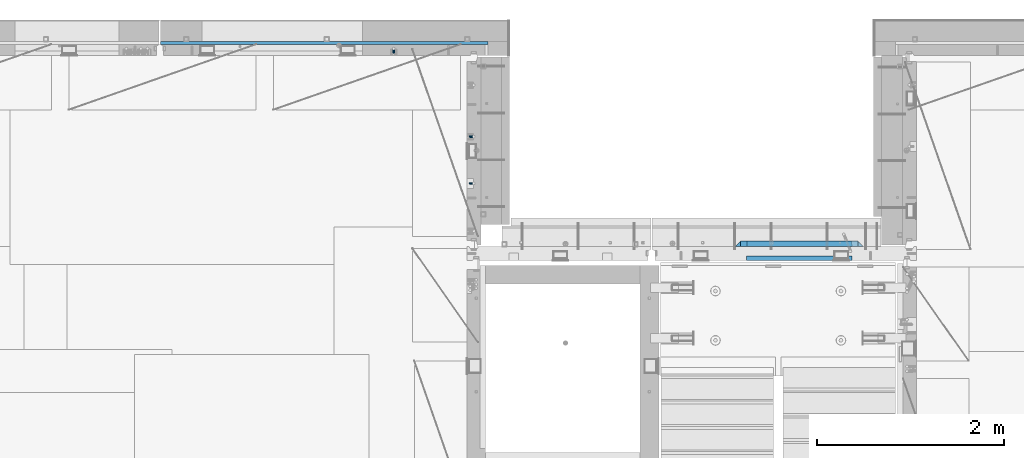
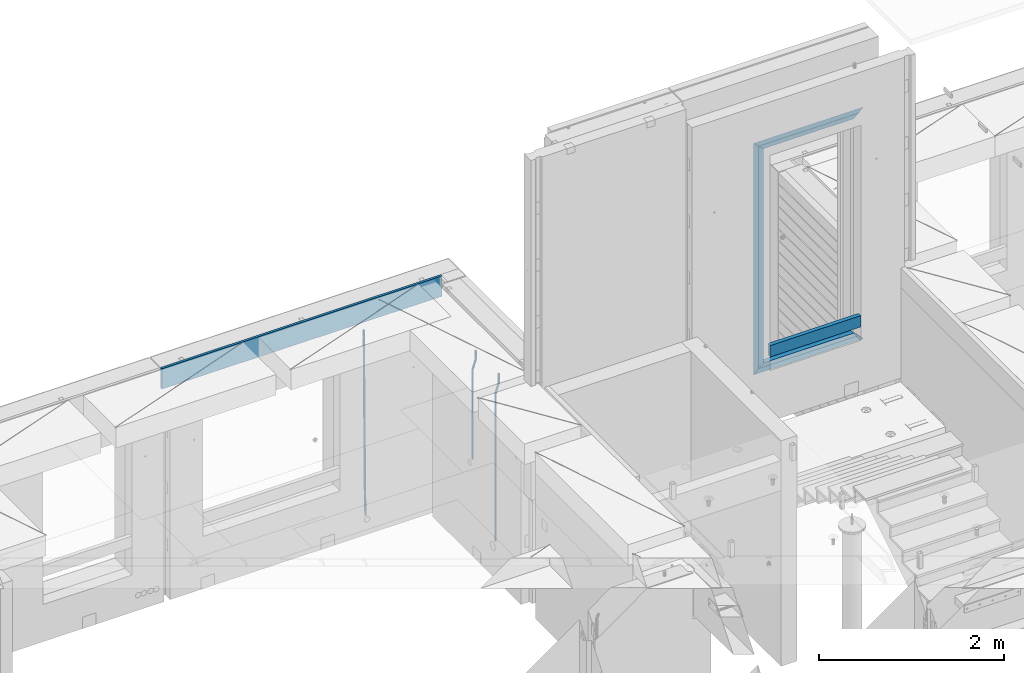
# One storey, part 122 of 352: 11 beams, 3 elements without a shape of their own.
"""IFC2X3 building model written with IfcOpenShell, lengths in millimetres."""

from ifc_helpers import new_model, si_unit, frame, origin_with_axes, place, context, subcontext, project, spatial, faceted_brep, material, type_object, element, aggregate, save


model = new_model("IFC2X3")

# Units and contexts
model_context = context("Model", 3, precision=1e-05, world=origin_with_axes())
body_context = subcontext(model_context, "Body", "Model", "MODEL_VIEW")
ifc_project = project(units=[si_unit("LENGTHUNIT", "METRE", prefix="MILLI"), si_unit("AREAUNIT", "SQUARE_METRE"), si_unit("VOLUMEUNIT", "CUBIC_METRE"), si_unit("MASSUNIT", "GRAM", prefix="KILO"), si_unit("TIMEUNIT", "SECOND"), si_unit("PLANEANGLEUNIT", "RADIAN"), si_unit("SOLIDANGLEUNIT", "STERADIAN"), si_unit("THERMODYNAMICTEMPERATUREUNIT", "DEGREE_CELSIUS"), si_unit("LUMINOUSINTENSITYUNIT", "LUMEN")], contexts=[model_context])

# Site, building, storey
site_placement = place(None, origin_with_axes())
site = spatial("IfcSite", under=ifc_project, at=site_placement, CompositionType="ELEMENT")
building_placement = place(site_placement, origin_with_axes())
building = spatial("IfcBuilding", under=site, at=building_placement, CompositionType="ELEMENT")
storey_placement = place(building_placement, origin_with_axes())
storey = spatial("IfcBuildingStorey", under=building, at=storey_placement, Name="6", CompositionType="ELEMENT", Elevation=0.0)

# Assembly, beam
assembly_1_placement = place(storey_placement, origin_with_axes())
assembly_1 = element("IfcElementAssembly", 1, at=assembly_1_placement, inside=storey, AssemblyPlace="NOTDEFINED", PredefinedType="REINFORCEMENT_UNIT")
ifc_material_1 = material()
beam_type_1 = type_object("IfcBeamType", Name="D20", PredefinedType="NOTDEFINED")
beam_1_placement = place(assembly_1_placement, frame((16830.0000000039, 22654.999995444, 96990.0), z_axis=(-0.000205762999925498, 0.999642804629538, -0.0267249099901004), x_axis=(4.30000201928125e-08, 0.0267249099948059, 0.999642825806181)))
beam_1 = element("IfcBeam", 2, at=beam_1_placement, type_object=beam_type_1, material=ifc_material_1, Name="JM20", ObjectType="D20", context=body_context, shape_type="Brep", body=[
    faceted_brep([(0.0, -10.0, 0.0), (-4.19531716033816e-08, -7.07106781186667, -7.07106781187031), (60.4266690400545, -7.0710677960451, -7.07106780570757), (60.4266690441291, -9.99999998418934, 6.15546014159918e-09), (0.0, 0.0, -10.0), (60.426669036824, 1.58106558956206e-08, -9.99999999384454), (4.196772351861e-08, 7.07106781186303, -7.07106781186667), (60.4266690363438, 7.07106782768096, -7.07106780570757), (0.0, 10.0, 0.0), (60.4266690388904, 10.0000000158179, 6.15182216279209e-09), (4.196772351861e-08, 7.07106781185939, 7.07106781185939), (60.4266690429649, 7.07106782768096, 7.07106781802577), (0.0, 0.0, 10.0), (60.4266690461809, 1.58179318532348e-08, 10.0000000061555), (-4.19531716033816e-08, -7.07106781187031, 7.07106781185939), (60.4266690466611, -7.07106779605238, 7.07106781802213), (61.0378400410118, -7.07106779588503, -7.07106780564936), (60.991799419251, -9.99999998403655, 6.21366780251265e-09), (61.0569027789461, 1.5985278878361e-08, -9.99999999378269), (61.0378209396877, 7.07106782784831, -7.07106780564936), (60.9917724058905, 10.0000000159635, 6.21366780251265e-09), (60.9457317841297, 7.07106782781193, 7.0710678180767), (60.9266690461809, 1.59488990902901e-08, 10.0000000062028), (60.9457508854539, -7.07106779591413, 7.0710678180767), (61.6489592143771, -7.07106614513759, -7.06310863441468), (61.5568818710308, -9.9999984576425, 0.00735959856683621), (61.6870830769039, 1.71821739058942e-06, -9.99179257185824), (61.6489210170112, 7.07106947854481, -7.06310888312146), (61.556827851804, 10.0000015422847, 0.00735924683976918), (61.4647505084577, 7.07106922979438, 7.07782747982128), (61.4266266459163, 1.36643211590126e-06, 10.0065114172685), (61.464788705809, -7.07106639389531, 7.07782772852806), (176.543135720174, -7.07075579406956, -5.56673531796696), (176.451058376813, -9.99968810657447, 1.50373291501455), (176.581259582701, 0.000312069292704109, -8.49541925541052), (176.543097522794, 7.07137982961285, -5.56673556667374), (176.451004357587, 10.00031189336, 1.50373256329476), (176.35892701424, 7.07137958085514, 8.57420079627263), (176.320803151699, 0.000311717507429421, 11.5028847337162), (176.358965211621, -7.07075604281999, 8.57420104497578), (177.098753836006, -7.07075429323595, -5.55949898843028), (176.98362511232, -9.99968666800123, 1.510669025065), (177.146421932586, 0.000313595905026887, -8.48805862247536), (177.098706077581, 7.07138133041735, -5.55949936166144), (176.983557571715, 10.0003133318824, 1.51066849724157), (176.868428848029, 7.07138095712435, 8.58083651073321), (176.820760751449, 0.000313067976094317, 11.5093961447819), (176.868476606425, -7.07075466652896, 8.58083688396073), (177.654312950661, -7.07075204110879, -5.54863964998367), (177.516135294456, -9.99968450931192, 1.52107783331303), (177.711524267797, 0.000315886711177882, -8.47701274570863), (177.654255632195, 7.07138358250813, -5.54864021007961), (177.516054233929, 10.0003154905207, 1.5210770412159), (177.377876577739, 7.0713830223176, 8.59079452451624), (177.320665260588, 0.000315094497636892, 11.5191676202448), (177.377933896176, -7.07075260129932, 8.59079508461218), (299.436796249574, -7.07025836271714, -3.1681962331204), (299.298618593355, -9.99919083092027, 3.90152125031091), (299.494007566798, 0.000809565110102994, -6.09656932889993), (299.436738931283, 7.07187726089978, -3.16819679320906), (299.298537533061, 10.0008091689197, 3.90152045822106), (299.160359876842, 7.07187670072017, 10.9712379416487), (299.103148559603, 0.000808772889286047, 13.8996110374392), (299.160417195119, -7.07025892290039, 10.9712385017483), (299.98743051647, -7.07025613056248, -3.15743315966392), (299.971788958996, -9.99918809853989, 3.91467979818117), (299.993912075952, 0.000811591617093654, -6.08679785393178), (299.987423933868, 7.07187949325817, -3.1574327280432), (299.971753863239, 10.0008119014747, 3.91467990454839), (299.95611230444, 7.07187992653053, 10.9867922621015), (299.949630744944, 0.000812204350950196, 13.9161569563694), (299.956118887014, -7.07025569729012, 10.9867918304735), (300.538107039494, -7.07025785017686, -3.16575821840888), (300.644985195438, -9.99919020432935, 3.90450175465594), (300.493854948218, 0.000810030429420294, -6.09435592770024), (300.538151196495, 7.071877773491, -3.16575855385963), (300.645047642858, 10.0008097955724, 3.90450128024895), (300.751925798773, 7.07187744142357, 10.9747612533101), (300.796177890064, 0.000809560813650023, 13.9033589625978), (300.751881641787, -7.07025818224065, 10.9747615887682), (2293.36490490142, -7.07648090940347, -33.2930642912361), (2293.47178305736, -10.0054132635523, -26.2228043181785), (2293.32065281013, -0.00541302880083094, -36.2216620005347), (2293.36494905842, 7.06565471425711, -33.2930646266868), (2293.47184550477, 9.99458673634581, -26.2228047925819), (2293.57872366071, 7.06565438219332, -19.1525448195243), (2293.62297575199, -0.00541349841296324, -16.2239471102366), (2293.57867950371, -7.0764812414709, -19.1525444840736), (2294.0658245362, -7.07648309818615, -33.3036607065333), (2294.05312277409, -10.0054150789219, -26.2315929392535), (2294.10928714235, -0.00541549149056664, -36.2335844756526), (2294.15805078732, 7.06565223761572, -33.3050546393533), (2294.18355038921, 9.99458451388637, -26.2335642579346), (2294.17084862708, 7.06565253314329, -19.1614964906439), (2294.12738602093, -0.00541507354500936, -16.2315727215355), (2294.07862237596, -7.07648280265857, -19.1601025578348), (2294.76670261032, -7.08562269121467, -33.294332712383), (2294.63442802057, -10.0129954178956, -26.2238563411993), (2294.89787471293, -0.0156988342423574, -36.2230891548279), (2294.95110548967, 7.05531064255774, -33.2944998654275), (2294.89521307347, 9.98530428734011, -26.2240927312887), (2294.76293848372, 7.0579315606592, -19.1536163601049), (2294.63176638114, -0.0119922963167483, -16.2248599176673), (2294.57853560438, -7.08300177311321, -19.1534492070678), (2316.52657204497, -7.36937582653991, -33.0047303660212), (2316.39429745522, -10.2967485532172, -25.9342539948302), (2316.65774414754, -0.299451969567599, -35.9334868084661), (2316.7109749243, 6.7715575072325, -33.0048975190657), (2316.65508250811, 9.70155115201487, -25.9344903849269), (2316.52280791836, 6.7741784253376, -18.8640140137468), (2316.39163581574, -0.295745431634714, -15.9352575713092), (2316.33840503903, -7.36675490843481, -18.863846860706), (2317.16202064224, -7.37766220584308, -32.9962731735213), (2317.05438744847, -10.3053562613532, -25.9254688497131), (2317.23607125619, -0.306993473008333, -35.925789846493), (2317.23316144495, 6.76474808850253, -32.9979477328052), (2317.15499573652, 9.6950321815566, -25.9278370341635), (2317.04736254275, 6.7673381260538, -18.8570327103698), (2316.97331192881, -0.303330606784584, -15.9275160373909), (2316.97622174003, -7.37507216829545, -18.8553581510787), (2317.79752306276, -7.37578610372293, -32.9880110666527), (2317.71453320107, -10.3033876998124, -25.9168792378296), (2317.81444760226, -0.305295583297266, -35.918287695793), (2317.75539265381, 6.76628640723357, -32.9911928173897), (2317.65495180529, 9.69652304524061, -25.9213789128698), (2317.5719619436, 6.76892144914746, -18.8502470840467), (2317.55503740412, -0.301569071270933, -15.9199704549137), (2317.61409235255, -7.3731510618054, -18.847065333317), (2417.8183084176, -7.07752398473531, -31.6906369377139), (2417.73531855589, -10.0051255808248, -24.6195051088798), (2417.83523295709, -0.007033464313281, -34.6209135668432), (2417.77617800863, 7.06454852621755, -31.6938186884508), (2417.67573716014, 9.99478516423187, -24.6240047839383), (2417.59274729842, 7.06718356813872, -17.5528729551006), (2417.57582275895, -0.00330695228694822, -14.6225963259749), (2417.6348777074, -7.07488894281778, -17.5496912043673)], [[[0, 1, 2, 3]], [[1, 4, 5, 2]], [[4, 6, 7, 5]], [[6, 8, 9, 7]], [[8, 10, 11, 9]], [[10, 12, 13, 11]], [[12, 14, 15, 13]], [[14, 0, 3, 15]], [[14, 12, 10, 8, 6, 4, 1, 0]], [[3, 2, 16, 17]], [[2, 5, 18, 16]], [[5, 7, 19, 18]], [[7, 9, 20, 19]], [[9, 11, 21, 20]], [[11, 13, 22, 21]], [[13, 15, 23, 22]], [[15, 3, 17, 23]], [[17, 16, 24, 25]], [[16, 18, 26, 24]], [[18, 19, 27, 26]], [[19, 20, 28, 27]], [[20, 21, 29, 28]], [[21, 22, 30, 29]], [[22, 23, 31, 30]], [[23, 17, 25, 31]], [[25, 24, 32, 33]], [[24, 26, 34, 32]], [[26, 27, 35, 34]], [[27, 28, 36, 35]], [[28, 29, 37, 36]], [[29, 30, 38, 37]], [[30, 31, 39, 38]], [[31, 25, 33, 39]], [[33, 32, 40, 41]], [[32, 34, 42, 40]], [[34, 35, 43, 42]], [[35, 36, 44, 43]], [[36, 37, 45, 44]], [[37, 38, 46, 45]], [[38, 39, 47, 46]], [[39, 33, 41, 47]], [[41, 40, 48, 49]], [[40, 42, 50, 48]], [[42, 43, 51, 50]], [[43, 44, 52, 51]], [[44, 45, 53, 52]], [[45, 46, 54, 53]], [[46, 47, 55, 54]], [[47, 41, 49, 55]], [[49, 48, 56, 57]], [[48, 50, 58, 56]], [[50, 51, 59, 58]], [[51, 52, 60, 59]], [[52, 53, 61, 60]], [[53, 54, 62, 61]], [[54, 55, 63, 62]], [[55, 49, 57, 63]], [[57, 56, 64, 65]], [[56, 58, 66, 64]], [[58, 59, 67, 66]], [[59, 60, 68, 67]], [[60, 61, 69, 68]], [[61, 62, 70, 69]], [[62, 63, 71, 70]], [[63, 57, 65, 71]], [[65, 64, 72, 73]], [[64, 66, 74, 72]], [[66, 67, 75, 74]], [[67, 68, 76, 75]], [[68, 69, 77, 76]], [[69, 70, 78, 77]], [[70, 71, 79, 78]], [[71, 65, 73, 79]], [[73, 72, 80, 81]], [[72, 74, 82, 80]], [[74, 75, 83, 82]], [[75, 76, 84, 83]], [[76, 77, 85, 84]], [[77, 78, 86, 85]], [[78, 79, 87, 86]], [[79, 73, 81, 87]], [[81, 80, 88, 89]], [[80, 82, 90, 88]], [[82, 83, 91, 90]], [[83, 84, 92, 91]], [[84, 85, 93, 92]], [[85, 86, 94, 93]], [[86, 87, 95, 94]], [[87, 81, 89, 95]], [[89, 88, 96, 97]], [[88, 90, 98, 96]], [[90, 91, 99, 98]], [[91, 92, 100, 99]], [[92, 93, 101, 100]], [[93, 94, 102, 101]], [[94, 95, 103, 102]], [[95, 89, 97, 103]], [[97, 96, 104, 105]], [[96, 98, 106, 104]], [[98, 99, 107, 106]], [[99, 100, 108, 107]], [[100, 101, 109, 108]], [[101, 102, 110, 109]], [[102, 103, 111, 110]], [[103, 97, 105, 111]], [[105, 104, 112, 113]], [[104, 106, 114, 112]], [[106, 107, 115, 114]], [[107, 108, 116, 115]], [[108, 109, 117, 116]], [[109, 110, 118, 117]], [[110, 111, 119, 118]], [[111, 105, 113, 119]], [[113, 112, 120, 121]], [[112, 114, 122, 120]], [[114, 115, 123, 122]], [[115, 116, 124, 123]], [[116, 117, 125, 124]], [[117, 118, 126, 125]], [[118, 119, 127, 126]], [[119, 113, 121, 127]], [[121, 120, 128, 129]], [[120, 122, 130, 128]], [[122, 123, 131, 130]], [[123, 124, 132, 131]], [[124, 125, 133, 132]], [[125, 126, 134, 133]], [[126, 127, 135, 134]], [[127, 121, 129, 135]], [[130, 131, 132, 133, 134, 135, 129, 128]]]),
])

# Assembly, beams
assembly_2_placement = place(storey_placement, origin_with_axes())
assembly_2 = element("IfcElementAssembly", 3, at=assembly_2_placement, inside=storey, AssemblyPlace="NOTDEFINED", PredefinedType="REINFORCEMENT_UNIT")
beam_2_placement = place(assembly_2_placement, frame((17685.0, 21755.0073333522, 99407.5), z_axis=(-0.999999913638316, 0.000415599999849952, 0.0), x_axis=(0.0, 0.0, -1.0)))
beam_2 = element("IfcBeam", 4, at=beam_2_placement, type_object=beam_type_1, material=ifc_material_1, Name="JM20", ObjectType="D20", context=body_context, shape_type="Brep", body=[
    faceted_brep([(0.0, -10.0, 0.0), (-4.19531716033816e-08, -7.07106781186667, -7.07106781187031), (113.248091332178, -7.0710684840451, -7.0710678117357), (113.248091314759, -10.0000006713562, -2.51020537689328e-10), (0.0, 0.0, -10.0), (113.248091374131, -6.72178430249915e-07, -9.99999999986903), (4.196772351861e-08, 7.07106781186303, -7.07106781186667), (113.248091416113, 7.07106713968824, -7.07106781173934), (0.0, 10.0, 0.0), (113.248091433488, 9.99999932782521, 1.30967237055302e-10), (4.196772351861e-08, 7.07106781185939, 7.07106781185939), (113.248091416113, 7.0710671396846, 7.071067811994), (0.0, 0.0, 10.0), (113.248091374131, -6.72174792271107e-07, 10.0000000001273), (-4.19531716033816e-08, -7.07106781187031, 7.07106781185939), (113.248091332178, -7.0710684840451, 7.071067811994), (130.699843527167, -7.06993249763036, -4.33745683788584), (128.538066582521, -9.99900540317321, 2.39499413731755), (131.594536475241, 0.00119355250353692, -7.12624594330919), (130.698046432328, 7.07220300913468, -4.33773834422391), (128.535525107087, 10.0009944322555, 2.39459602660281), (126.373748162892, 7.07192152754578, 9.1270470011732), (125.479055214906, 0.000795477419160306, 11.9158361066184), (126.37554525779, -7.07021397921199, 9.12732850753673), (240.336258550378, -7.05529970173666, 30.8729495437874), (238.174481606227, -9.98437260450009, 37.6054005176375), (241.230951498423, 0.0158263482953771, 28.0841604381058), (240.334461455612, 7.0868358050102, 30.8726680369582), (238.171940130502, 10.0156272283348, 37.6050024077231), (236.010163186409, 7.08655432384694, 44.3374533824244), (235.115470238379, 0.0154282738185429, 47.1262424881097), (236.011960281176, -7.05558118289991, 44.3377348892536), (253.461915329972, -7.05444528127919, 32.9289287376414), (253.46191532613, -9.98337746617108, 39.9999965521893), (253.461915339081, 0.0166225284556276, 29.9999965443676), (253.461915348205, 7.08769034247234, 32.9289287273205), (253.461915352003, 10.0166225357716, 39.9999965370152), (253.461915348293, 7.08769035281148, 47.0710643509774), (253.461915339183, 0.0166225430875784, 49.999996544273), (253.46191533003, -7.05444527093641, 47.0710643613093), (1417.49999998364, -7.05444797759628, 32.9289287358552), (1417.49999997689, -9.98338016170965, 39.9999965493844), (1417.49999999996, 0.0166198326005542, 29.9999965436982), (1417.50000001628, 7.08768764613342, 32.9289287278079), (1417.50000002306, 10.0166198382904, 39.9999965380084), (1417.5000000163, 7.08768765417699, 47.0710643515376), (1417.49999999999, 0.0166198439801519, 49.9999965436946), (1417.49999998366, -7.05444796955271, 47.0710643595849)], [[[0, 1, 2, 3]], [[1, 4, 5, 2]], [[4, 6, 7, 5]], [[6, 8, 9, 7]], [[8, 10, 11, 9]], [[10, 12, 13, 11]], [[12, 14, 15, 13]], [[14, 0, 3, 15]], [[14, 12, 10, 8, 6, 4, 1, 0]], [[3, 2, 16, 17]], [[2, 5, 18, 16]], [[5, 7, 19, 18]], [[7, 9, 20, 19]], [[9, 11, 21, 20]], [[11, 13, 22, 21]], [[13, 15, 23, 22]], [[15, 3, 17, 23]], [[17, 16, 24, 25]], [[16, 18, 26, 24]], [[18, 19, 27, 26]], [[19, 20, 28, 27]], [[20, 21, 29, 28]], [[21, 22, 30, 29]], [[22, 23, 31, 30]], [[23, 17, 25, 31]], [[25, 24, 32, 33]], [[24, 26, 34, 32]], [[26, 27, 35, 34]], [[27, 28, 36, 35]], [[28, 29, 37, 36]], [[29, 30, 38, 37]], [[30, 31, 39, 38]], [[31, 25, 33, 39]], [[33, 32, 40, 41]], [[32, 34, 42, 40]], [[34, 35, 43, 42]], [[35, 36, 44, 43]], [[36, 37, 45, 44]], [[37, 38, 46, 45]], [[38, 39, 47, 46]], [[39, 33, 41, 47]], [[42, 43, 44, 45, 46, 47, 41, 40]]]),
])
beam_type_2 = type_object("IfcBeamType", Name="D25", PredefinedType="NOTDEFINED")
beam_3_placement = place(assembly_2_placement, frame((17685.0, 21255.0073333522, 99407.5), z_axis=(-0.999999913638316, 0.000415599999849952, 0.0), x_axis=(0.0, 0.0, -1.0)))
beam_3 = element("IfcBeam", 5, at=beam_3_placement, type_object=beam_type_2, material=ifc_material_1, Name="JM25", ObjectType="D25", context=body_context, shape_type="Brep", body=[
    faceted_brep([(-7.41420080885291e-08, -12.5, -3.63797880709171e-12), (-6.42030499875546e-08, -10.8253175473074, -6.25000000000364), (113.248091310059, -10.8253182190492, -6.25000000001091), (113.248091299931, -12.5000006708469, -2.80124368146062e-10), (-3.70782800018787e-08, -6.25000000000364, -10.8253175473074), (113.248091337184, -6.25000067174187, -10.8253175473183), (-1.45519152283669e-11, -3.63797880709171e-12, -12.5), (113.248091374247, -6.71741872793064e-07, -12.5000000000109), (3.70637280866504e-08, 6.25, -10.8253175473074), (113.248091411326, 6.24999932825813, -10.8253175473183), (6.42030499875546e-08, 10.8253175473001, -6.25000000000364), (113.248091438465, 10.8253168755618, -6.25000000001091), (7.41420080885291e-08, 12.4999999999927, 0.0), (113.248091448404, 12.4999993282545, -1.09139364212751e-11), (6.42176019027829e-08, 10.8253175473001, 6.24999999999636), (113.24809143848, 10.8253168755618, 6.24999999998545), (3.70928319171071e-08, 6.24999999999636, 10.8253175473037), (113.248091411355, 6.24999932825449, 10.8253175472928), (1.45519152283669e-11, -3.63797880709171e-12, 12.4999999999964), (113.248091374277, -6.71741872793064e-07, 12.4999999999854), (-3.7049176171422e-08, -6.25000000000364, 10.8253175473001), (113.248091337213, -6.25000067174187, 10.8253175472928), (-6.41884980723262e-08, -10.8253175473074, 6.25), (113.248091310074, -10.8253182190492, 6.24999999998909), (130.449259230882, -10.8241986432586, -3.55564009493173), (128.538384125903, -12.4990054706068, 2.39504387892885), (131.847691315706, -6.24879007587151, -7.91190976778307), (132.358971633032, 0.00124320192480809, -9.50650619965018), (131.846103034666, 6.25120982069348, -7.91215856435883), (130.446508247391, 10.826436272193, -3.55607102324211), (128.535207564215, 12.5009943235709, 2.39454628487874), (126.624332459658, 10.8261874972886, 8.34523025788076), (125.225900374833, 6.25077892990521, 12.7014999307248), (124.714620057581, 0.000745652105251793, 14.2960963626065), (125.227488655888, -6.24922096664886, 12.7017487273151), (126.62708344312, -10.8244474181665, 8.3456611861875), (240.085674248156, -10.8095671496994, 31.6547662857156), (238.174799143511, -12.4843739739517, 37.6054502584157), (241.484106332937, -6.23415858247972, 27.2984966126423), (241.995386650233, 0.0158746952838555, 25.703900180506), (241.482518051911, 6.26584131414347, 27.2982478155536), (240.082923264708, 10.8410677658503, 31.6543353565175), (238.171622581605, 12.5156258174902, 37.6049526646493), (236.260747477107, 10.8408189914335, 43.5556366377568), (234.862315392325, 6.26541042421377, 47.9119063108337), (234.351035075029, 0.0153771464501915, 49.5065027429664), (234.863903673351, -6.23458947240579, 47.9121551079224), (236.263498460554, -10.8098159241163, 43.5560675669512), (253.461915305525, -10.8086965039183, 33.7499965486895), (253.461915300941, -12.4833789551158, 39.9999965501447), (253.461915317355, -6.23337895905206, 29.1746789989811), (253.461915333464, 0.0166210400311684, 27.4999965429452), (253.461915349588, 6.26662104088609, 29.1746789923018), (253.461915361389, 10.8419385905909, 33.7499965371353), (253.461915365653, 12.5166210465904, 39.9999965362076), (253.461915361288, 10.8419385972084, 46.2499965370662), (253.461915349428, 6.26662105234573, 50.8253140867819), (253.461915333304, 0.0166210532552213, 52.4999965428069), (253.461915317152, -6.23337894759607, 50.8253140934612), (253.461915305408, -10.8086964973008, 46.2499965486277), (2197.49999997206, -10.8087015173915, 33.749996548926), (2197.49999996777, -12.4833839668026, 39.9999965498064), (2197.49999998385, -6.23338397248881, 29.1746789992176), (2197.49999999997, 0.0166160266307998, 27.4999965432398), (2197.50000001608, 6.26661602751119, 29.1746789926474), (2197.5000000279, 10.8419335772196, 33.74999653755), (2197.5000000322, 12.5166160331937, 39.9999965366696), (2197.50000002791, 10.8419335837862, 46.2499965375537), (2197.50000001611, 6.26661603888351, 50.8253140872584), (2197.5, 0.0166160397602653, 52.4999965432398), (2197.49999998388, -6.23338396111649, 50.825314093825), (2197.49999997209, -10.8087015108249, 46.2499965489224)], [[[0, 1, 2, 3]], [[1, 4, 5, 2]], [[4, 6, 7, 5]], [[6, 8, 9, 7]], [[8, 10, 11, 9]], [[10, 12, 13, 11]], [[12, 14, 15, 13]], [[14, 16, 17, 15]], [[16, 18, 19, 17]], [[18, 20, 21, 19]], [[20, 22, 23, 21]], [[22, 0, 3, 23]], [[22, 20, 18, 16, 14, 12, 10, 8, 6, 4, 1, 0]], [[3, 2, 24, 25]], [[2, 5, 26, 24]], [[5, 7, 27, 26]], [[7, 9, 28, 27]], [[9, 11, 29, 28]], [[11, 13, 30, 29]], [[13, 15, 31, 30]], [[15, 17, 32, 31]], [[17, 19, 33, 32]], [[19, 21, 34, 33]], [[21, 23, 35, 34]], [[23, 3, 25, 35]], [[25, 24, 36, 37]], [[24, 26, 38, 36]], [[26, 27, 39, 38]], [[27, 28, 40, 39]], [[28, 29, 41, 40]], [[29, 30, 42, 41]], [[30, 31, 43, 42]], [[31, 32, 44, 43]], [[32, 33, 45, 44]], [[33, 34, 46, 45]], [[34, 35, 47, 46]], [[35, 25, 37, 47]], [[37, 36, 48, 49]], [[36, 38, 50, 48]], [[38, 39, 51, 50]], [[39, 40, 52, 51]], [[40, 41, 53, 52]], [[41, 42, 54, 53]], [[42, 43, 55, 54]], [[43, 44, 56, 55]], [[44, 45, 57, 56]], [[45, 46, 58, 57]], [[46, 47, 59, 58]], [[47, 37, 49, 59]], [[49, 48, 60, 61]], [[48, 50, 62, 60]], [[50, 51, 63, 62]], [[51, 52, 64, 63]], [[52, 53, 65, 64]], [[53, 54, 66, 65]], [[54, 55, 67, 66]], [[55, 56, 68, 67]], [[56, 57, 69, 68]], [[57, 58, 70, 69]], [[58, 59, 71, 70]], [[59, 49, 61, 71]], [[62, 63, 64, 65, 66, 67, 68, 69, 70, 71, 61, 60]]]),
])
aggregate(assembly_2, [beam_3, beam_2])

assembly_3_placement = place(storey_placement, origin_with_axes())
assembly_3 = element("IfcElementAssembly", 6, at=assembly_3_placement, inside=storey, AssemblyPlace="NOTDEFINED", PredefinedType="REINFORCEMENT_UNIT")
ifc_material_2 = material(Name="TIMBER/T24")
beam_type_3 = type_object("IfcBeamType", PredefinedType="NOTDEFINED")
beam_4_placement = place(assembly_3_placement, frame((21724.9984049797, 20455.0, 99180.0), z_axis=(0.0, 0.0, 1.0), x_axis=(-1.0, 3.00000001838171e-08, 0.0)))
beam_4 = element("IfcBeam", 7, at=beam_4_placement, type_object=beam_type_3, material=ifc_material_2, context=body_context, shape_type="Brep", body=[
    faceted_brep([(-3.63797880709171e-12, 24.9999999999964, -75.0), (-3.63797880709171e-12, 24.9999999999964, 75.0), (1130.0, 25.0, 75.0), (1130.0, 25.0, -75.0), (0.0, -25.0000000000073, 75.0), (1130.0, -25.0, 75.0), (0.0, -25.0000000000073, -75.0), (1130.0, -25.0, -75.0)], [[[0, 1, 2, 3]], [[1, 4, 5, 2]], [[4, 6, 7, 5]], [[6, 0, 3, 7]], [[5, 7, 3, 2]], [[6, 4, 1, 0]]]),
])
ifc_material_3 = material(Name="CONCRETE/C25/30")
beam_type_4 = type_object("IfcBeamType", PredefinedType="NOTDEFINED")
beam_5_placement = place(assembly_3_placement, frame((21844.9984049797, 20610.0000000447, 101845.0), z_axis=(0.0, 0.0, -1.0), x_axis=(-1.0, 3.00000001838171e-08, 0.0)))
beam_5 = element("IfcBeam", 8, at=beam_5_placement, type_object=beam_type_4, material=ifc_material_3, context=body_context, shape_type="Brep", body=[
    faceted_brep([(60.0000000000073, 30.0, 30.0), (0.0, -30.0, -30.0), (60.0000000000073, -30.0, 30.0), (1310.0, 30.0, 30.0), (1370.0, -30.0, -30.0), (1310.0, -30.0, 30.0)], [[[0, 1, 2]], [[3, 4, 1, 0]], [[5, 2, 1, 4]], [[2, 5, 3, 0]], [[5, 4, 3]]]),
])
beam_6_placement = place(assembly_3_placement, frame((21784.9984049797, 20609.9999988829, 101785.0), z_axis=(0.0, 0.0, -1.0), x_axis=(-1.0, 3.00000001838171e-08, 0.0)))
beam_6 = element("IfcBeam", 9, at=beam_6_placement, type_object=beam_type_4, material=ifc_material_3, context=body_context, shape_type="Brep", body=[
    faceted_brep([(0.0, -30.0, -30.0), (64.0540540540533, -30.0, 24.9034748914419), (65.6756756756768, 30.0, 26.293436281092), (0.0, 30.0, -30.0), (64.0540540540533, -30.0, 24.0540540540533), (65.6756756756768, 30.0, 25.6756756756804), (1185.94594588314, -29.9999988381387, 24.0540541168593), (1184.32432432432, 29.9999988381387, 25.6756756756804), (1184.32432432432, 29.9999988381387, 26.2934362810629), (1250.0, 29.9999988381387, -30.0), (1250.0, -29.9999988381387, -30.0), (1185.94594588314, -29.9999988381387, 24.9034749452549)], [[[0, 1, 2, 3]], [[4, 5, 2, 1]], [[6, 7, 5, 4]], [[3, 2, 5, 7, 8, 9]], [[0, 3, 9, 10]], [[6, 4, 1, 0, 10, 11]], [[7, 6, 11, 8]], [[10, 9, 8, 11]]]),
])
beam_7_placement = place(assembly_3_placement, frame((20504.9984049797, 20610.0000000447, 101875.0), z_axis=(1.0, 0.0, 0.0), x_axis=(0.0, 0.0, -1.0)))
beam_7 = element("IfcBeam", 10, at=beam_7_placement, type_object=beam_type_4, material=ifc_material_3, context=body_context, shape_type="Brep", body=[
    faceted_brep([(60.0000000000073, 30.0, 30.0), (0.0, -30.0, -30.0), (60.0000000000073, -30.0, 30.0), (2995.00000000001, -30.0, 30.0), (3055.0, -30.0, -30.0), (2995.00000000001, 30.0, 30.0)], [[[0, 1, 2]], [[3, 2, 1, 4]], [[3, 4, 5]], [[2, 3, 5, 0]], [[4, 1, 0, 5]]]),
])
beam_8_placement = place(assembly_3_placement, frame((20474.9984049797, 20610.0000000447, 98850.0), z_axis=(0.0, 0.0, 1.0), x_axis=(1.0, 0.0, 0.0)))
beam_8 = element("IfcBeam", 11, at=beam_8_placement, type_object=beam_type_4, material=ifc_material_3, context=body_context, shape_type="Brep", body=[
    faceted_brep([(1310.0, -30.0, 30.0), (1370.0, -30.0, -30.0), (1310.0, 30.0, 30.0), (60.0000000000073, -30.0, 30.0), (60.0000000000073, 30.0, 30.0), (0.0, -30.0, -30.0)], [[[0, 1, 2]], [[3, 0, 2, 4]], [[4, 5, 3]], [[0, 3, 5, 1]], [[2, 1, 5, 4]]]),
])
beam_9_placement = place(assembly_3_placement, frame((20534.9984049797, 20609.9999988829, 98910.0), z_axis=(0.0, 0.0, 1.0), x_axis=(1.0, 0.0, 0.0)))
beam_9 = element("IfcBeam", 12, at=beam_9_placement, type_object=beam_type_4, material=ifc_material_3, context=body_context, shape_type="Brep", body=[
    faceted_brep([(1250.0, -29.9999988381387, -30.0), (1250.0, 29.9999988381387, -30.0), (1184.32432432432, 29.9999988381387, 26.2934362810629), (1185.94594588314, -29.9999988381387, 24.9034749452549), (1184.32432432432, 29.9999988381387, 25.6756756756804), (1185.94594588314, -29.9999988381387, 24.0540541168593), (65.6756756756768, 30.0, 25.6756756756804), (64.0540540540533, -30.0, 24.0540540540533), (65.6756756756768, 30.0, 26.293436281092), (64.0540540540533, -30.0, 24.9034748914419), (0.0, -30.0, -30.0), (0.0, 30.0, -30.0)], [[[0, 1, 2, 3]], [[4, 5, 3, 2]], [[5, 4, 6, 7]], [[7, 6, 8, 9]], [[5, 7, 9, 10, 0, 3]], [[10, 11, 1, 0]], [[11, 8, 6, 4, 2, 1]], [[10, 9, 8, 11]]]),
])
beam_type_5 = type_object("IfcBeamType", PredefinedType="NOTDEFINED")
beam_10_placement = place(assembly_3_placement, frame((20569.9984049797, 20609.9999988829, 101815.0), z_axis=(1.0, 0.0, 0.0), x_axis=(0.0, 0.0, -1.0)))
beam_10 = element("IfcBeam", 13, at=beam_10_placement, type_object=beam_type_5, material=ifc_material_3, context=body_context, shape_type="Brep", body=[
    faceted_brep([(0.0, -30.0, -35.0), (54.9034748914273, -30.0, 29.0540540540533), (56.2934362811066, 30.0, 30.6756756756768), (0.0, 30.0, -35.0), (2878.70656371892, 29.9999988381387, 30.6756756756768), (2935.0, 29.9999988381387, -35.0), (2935.0, -29.9999988381387, -35.0), (2880.09652505475, -29.9999988381387, 29.0540541168593)], [[[0, 1, 2, 3]], [[3, 2, 4, 5]], [[0, 3, 5, 6]], [[1, 0, 6, 7]], [[2, 1, 7, 4]], [[6, 5, 4, 7]]]),
])
aggregate(assembly_3, [beam_5, beam_6, beam_7, beam_10, beam_8, beam_9, beam_4])

# Beam
beam_type_6 = type_object("IfcBeamType", Name="270X30", PredefinedType="NOTDEFINED")
beam_11_placement = place(assembly_1_placement, frame((17835.0, 22755.0, 99605.0), z_axis=(0.0, 0.0, 1.0), x_axis=(-1.0, 3.00000001838171e-08, 0.0)))
beam_11 = element("IfcBeam", 14, at=beam_11_placement, type_object=beam_type_6, material=ifc_material_3, ObjectType="270X30", context=body_context, shape_type="Brep", body=[
    faceted_brep([(0.0, 15.0, -135.0), (0.0, 15.0, 135.0), (3495.00000000002, 15.0, 135.0), (3495.00000000002, 15.0, -135.0), (0.0, -15.0, 135.0), (3495.00000000002, -15.0, 135.0), (0.0, -15.0, -135.0), (3495.00000000002, -15.0, -135.0)], [[[0, 1, 2, 3]], [[1, 4, 5, 2]], [[4, 6, 7, 5]], [[6, 0, 3, 7]], [[5, 7, 3, 2]], [[6, 4, 1, 0]]]),
])

aggregate(assembly_1, [beam_1, beam_11])

save(model, "model.ifc")
